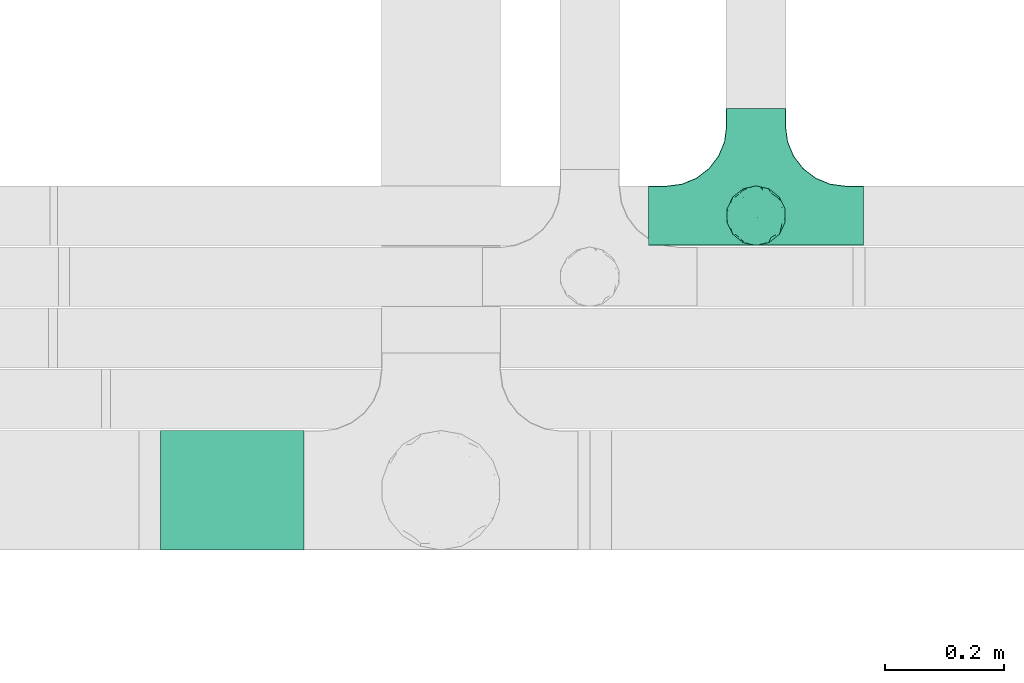
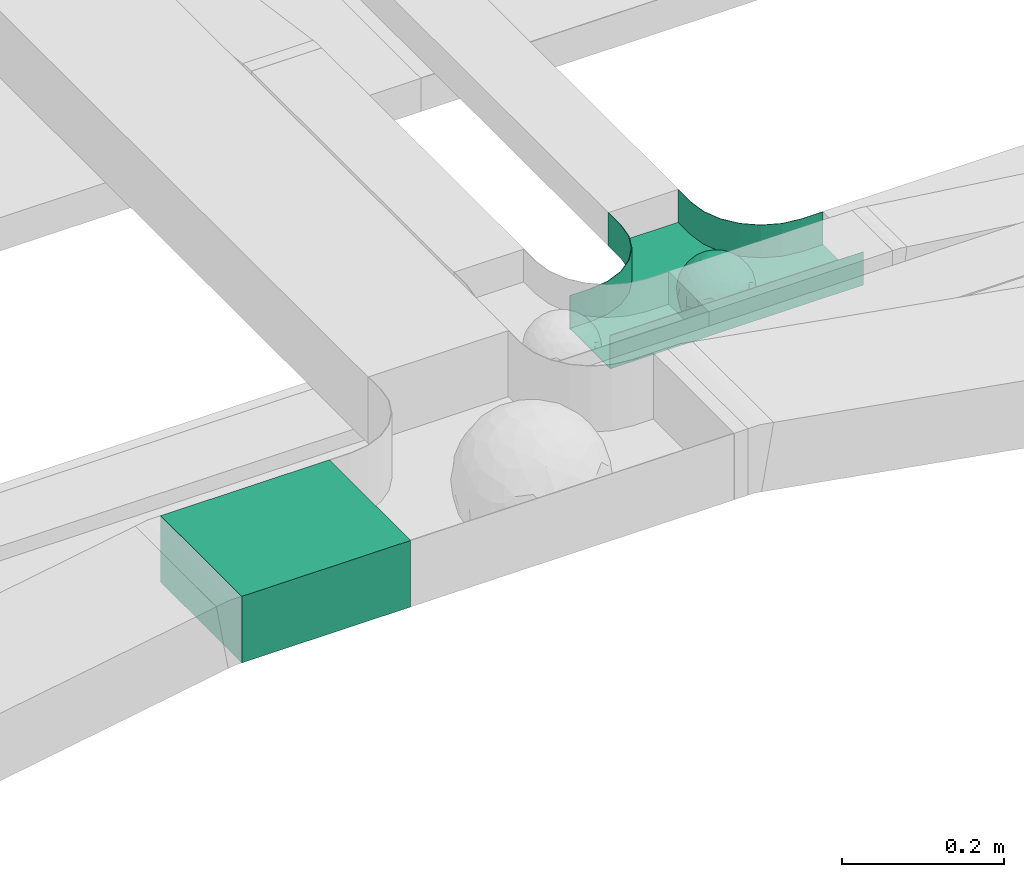
# One storey, part 13 of 38: 1 flow fitting, 1 flow segment.
"""IFC2X3 building model written with IfcOpenShell, lengths in millimetres."""

from ifc_helpers import new_model, entity, si_unit, converted_unit, derived_unit, direction, frame, frame_2d, origin, place, context, subcontext, project, spatial, rectangle, extrude, faceted_brep, source, transform, mapped, material, material_list, type_object, type_shapes, element, save


model = new_model("IFC2X3")

# Units and contexts
model_context = context("Model", 3, precision=0.01, world=origin(), true_north=direction((6.12303176911189e-17, 1.0)))
body_context = subcontext(model_context, "Body", "Model", "MODEL_VIEW")
ifc_project = project(units=[si_unit("LENGTHUNIT", "METRE", prefix="MILLI"), si_unit("AREAUNIT", "SQUARE_METRE"), si_unit("VOLUMEUNIT", "CUBIC_METRE"), converted_unit("PLANEANGLEUNIT", "DEGREE", entity("IfcRatioMeasure", 0.0174532925199433), si_unit("PLANEANGLEUNIT", "RADIAN"), dimensions=[0, 0, 0, 0, 0, 0, 0]), si_unit("MASSUNIT", "GRAM", prefix="KILO"), derived_unit("MASSDENSITYUNIT", [(si_unit("MASSUNIT", "GRAM", prefix="KILO"), 1), (si_unit("LENGTHUNIT", "METRE"), -3)]), derived_unit("MOMENTOFINERTIAUNIT", [(si_unit("LENGTHUNIT", "METRE"), 4)]), si_unit("TIMEUNIT", "SECOND"), si_unit("FREQUENCYUNIT", "HERTZ"), si_unit("THERMODYNAMICTEMPERATUREUNIT", "DEGREE_CELSIUS"), derived_unit("THERMALTRANSMITTANCEUNIT", [(si_unit("MASSUNIT", "GRAM", prefix="KILO"), 1), (si_unit("THERMODYNAMICTEMPERATUREUNIT", "KELVIN"), -1), (si_unit("TIMEUNIT", "SECOND"), -3)]), derived_unit("VOLUMETRICFLOWRATEUNIT", [(si_unit("LENGTHUNIT", "METRE"), 3), (si_unit("TIMEUNIT", "SECOND"), -1)]), derived_unit("MASSFLOWRATEUNIT", [(si_unit("MASSUNIT", "GRAM", prefix="KILO"), 1), (si_unit("TIMEUNIT", "SECOND"), -1)]), derived_unit("ROTATIONALFREQUENCYUNIT", [(si_unit("TIMEUNIT", "SECOND"), -1)]), si_unit("ELECTRICCURRENTUNIT", "AMPERE"), si_unit("ELECTRICVOLTAGEUNIT", "VOLT"), si_unit("POWERUNIT", "WATT"), si_unit("FORCEUNIT", "NEWTON", prefix="KILO"), si_unit("ILLUMINANCEUNIT", "LUX"), si_unit("LUMINOUSFLUXUNIT", "LUMEN"), si_unit("LUMINOUSINTENSITYUNIT", "CANDELA"), derived_unit("USERDEFINED", [(si_unit("MASSUNIT", "GRAM", prefix="KILO"), -1), (si_unit("LENGTHUNIT", "METRE"), -2), (si_unit("TIMEUNIT", "SECOND"), 3), (si_unit("LUMINOUSFLUXUNIT", "LUMEN"), 1)]), derived_unit("LINEARVELOCITYUNIT", [(si_unit("LENGTHUNIT", "METRE"), 1), (si_unit("TIMEUNIT", "SECOND"), -1)]), si_unit("PRESSUREUNIT", "PASCAL"), derived_unit("USERDEFINED", [(si_unit("LENGTHUNIT", "METRE"), -2), (si_unit("MASSUNIT", "GRAM", prefix="KILO"), 1), (si_unit("TIMEUNIT", "SECOND"), -2)]), derived_unit("LINEARFORCEUNIT", [(si_unit("MASSUNIT", "GRAM", prefix="KILO"), 1), (si_unit("LENGTHUNIT", "METRE"), 1), (si_unit("TIMEUNIT", "SECOND"), -2), (si_unit("LENGTHUNIT", "METRE"), -1)]), derived_unit("PLANARFORCEUNIT", [(si_unit("MASSUNIT", "GRAM", prefix="KILO"), 1), (si_unit("LENGTHUNIT", "METRE"), 1), (si_unit("TIMEUNIT", "SECOND"), -2), (si_unit("LENGTHUNIT", "METRE"), -2)])], contexts=[model_context])

# Site, building, storey
site_placement = place(None, frame((0.0, -0.00077364408347762, 0.0)))
site = spatial("IfcSite", under=ifc_project, at=site_placement, CompositionType="ELEMENT")
building_placement = place(site_placement, origin())
building = spatial("IfcBuilding", under=site, at=building_placement, CompositionType="ELEMENT")
storey_placement = place(building_placement, frame((0.0, 0.0, 4200.0)))
storey = spatial("IfcBuildingStorey", under=building, at=storey_placement, CompositionType="ELEMENT", Elevation=4200.0)

# Flow segment
cable_carrier_segment_type = type_object("IfcCableCarrierSegmentType", PredefinedType="CABLETRAYSEGMENT")
flow_segment_placement = place(storey_placement, frame((14113.434285659, 11443.7857236441, 2904.05791329438)))
element("IfcFlowSegment", 1, at=flow_segment_placement, inside=storey, type_object=cable_carrier_segment_type, context=body_context, shape_type="SweptSolid", body=[
    extrude(rectangle(XDim=240.106415937877, YDim=200.000000000002, at=frame_2d((1.08002495835535e-12, 0.0), x_axis=(1.0, 0.0))), frame((120.053207968937, 100.0, 0.0), z_axis=(0.0, 0.0, 1.0), x_axis=(-1.0, 0.0, 0.0)), (0.0, 0.0, 1.0), 99.9999999999989),
])

# Flow fitting
ifc_material_1 = material()
ifc_material_2 = material()
ifc_material_list = material_list([ifc_material_1, ifc_material_2])
cable_carrier_fitting_type = type_object("IfcCableCarrierFittingType", PredefinedType="NOTDEFINED", material=ifc_material_1)
shared_shape = source(origin(), body_context, "Body", "Brep", [
    faceted_brep([(43.65414201495, -13.6159823941412, -20.221792907194), (44.7734537304832, 0.0, -22.2561865791168), (48.2627667869764, -5.5982238187369, -11.8053052540677), (16.6591030416451, 5.32882774998004, -46.8409850521773), (11.5556000970565, -8.32997143460759, -47.9278591457525), (2.01883462715812, 2.6979389970297, -49.8863250993269), (-7.81264210311725, -35.946586740035, -33.8645171988286), (-17.2052206683237, -38.2719861359275, -27.1888848422606), (-11.1277274207927, -27.3202044092451, -40.3705352142543), (37.7030088371667, -7.24923843471304, -32.0301680723234), (10.6384317789277, 26.5155476513889, -41.0335168128579), (19.2127839264957, 19.8412508508062, -41.6796556903778), (10.4192511908907, 17.8098221318595, -45.5439286870577), (48.7463956090969, 0.0, 0.0), (48.0667721403428, 6.51594663441988, -12.1296271775358), (-37.4554170352858, 12.1627069007925, -30.8084451986326), (-31.3452178059555, 12.1462454498318, -37.0127821457472), (-38.0909108580228, 3.52194087904066, -32.1974912446565), (48.7463956090969, 11.1260466978072, 0.0), (9.66670567763161, 42.5651334019307, -24.3877883338551), (17.4761229293595, 37.974251726212, -27.4324868211278), (8.3452685270067, 35.3634447252368, -34.3479733081336), (36.7018152786982, 20.4309971840494, -27.121045505536), (28.2201055605836, 12.5803931374896, -39.3110588849404), (28.3969378462537, 24.0066360557188, -33.4259681422047), (37.1036906899333, 7.75177236926259, -32.6071489449891), (30.3928805396455, 38.1114667440203, 0.0), (34.7422273315263, 34.6429784184742, 0.0), (32.9402906787036, 32.1278050479557, -19.5637775698511), (26.0435337477646, 41.5799550695664, 0.0), (-44.7734518080776, 0.0, -22.2561904464559), (-35.9183276906112, -8.71634506105637, -33.6734177755349), (-42.698067512074, -12.1858404892465, -22.9865247983333), (5.42354673897514, -48.7621108487887, 0.0), (2.92058716488888e-07, -48.7843224693665, -10.9585528791684), (7.58713024513234, -47.4313421101439, -13.8817592643935), (33.995370401777, -31.6485911362954, -18.5116576873667), (40.0066375577234, -26.2448741379086, -14.5146661281262), (30.3928805396453, -38.1114667440373, 0.0), (-47.5540080368347, -8.6499737676748, -12.798213682019), (43.918984866252, -21.1502683953847, 0.0), (-47.5463631702337, 8.67950108284767, -12.8066236860544), (-43.9189848662407, 21.1502683953677, 0.0), (-41.5587306666804, 23.544384411141, -14.7828910593852), (-36.7018137075475, 20.43099797302, -27.1210470373429), (-42.6812093094125, 12.162707383776, -23.0300438771125), (-0.0435489182880873, -44.6798423199703, -22.4434799831651), (43.3459115209922, 13.125713179152, -21.1860238825719), (-9.67158541810518, -42.815796006327, -23.9430166822217), (2.9348104480415, -38.3026865671621, -32.0045479482528), (10.5768620896568, -32.3565839798164, -36.6221444141874), (17.476122931187, -37.9742517249799, -27.4324868216925), (29.4150529887209, -14.2918330913411, -37.8219270339311), (29.2594402117981, 0.0, -40.5448536622337), (-34.742227331515, 34.6429784184742, 0.0), (-35.5934709721032, 30.8679809236437, -16.7413433706631), (16.2706402169142, 46.2863325463322, 0.0), (15.3978227309257, 45.3692296018892, -14.301750259225), (10.8470934779447, 47.524221697552, 0.0), (-22.0930685137321, 42.2576087042555, -15.0396419586498), (-16.2706402169028, 46.2863325463322, 0.0), (-15.3976096147999, 45.3685960862683, -14.3039892096614), (-35.5741674477324, -30.877857614309, -16.7641438657341), (-34.7422273315149, -34.6429784184913, 0.0), (-41.544749127214, -23.5699215759022, -14.7814957586296), (-21.2012609977656, -29.9118129495041, -33.9969113035032), (-22.0930685137892, -42.2576087036302, -15.0396419603704), (-28.5890959469058, -35.7745555449591, -20.0709932115786), (27.967317375364, -26.9235432392394, -31.5111405422078), (26.5630985649032, -36.7540375314827, -21.0604491824418), (-4.69743067705244, -12.8233951627736, -48.0988012484001), (-3.71385705669819, -22.0483048804436, -44.7222485756373), (7.046128924104e-07, -29.8515321197025, -40.1109215813634), (-8.78090686085946, 23.4705297392872, -43.266960933916), (-10.7087237416586, 12.1533783795858, -47.3034737602475), (-19.1851128431225, 19.8122800241045, -41.7061746680507), (19.2127839279743, -19.841250849511, -41.6796556903208), (10.2736167511021, -43.2535488218696, -22.8819429499797), (-16.2706402169027, -46.2863325463492, 0.0), (-15.4179487650123, -45.4307793041134, -14.0830091848577), (-10.8470934779332, -47.524221697569, 0.0), (-21.6941869558721, -45.0484433951294, 0.0), (-26.043533747753, -41.5799550695834, 0.0), (-30.3928805396339, -38.1114667440373, 0.0), (-26.9077773704145, -11.7097120961444, -40.4827637348157), (-28.5735237959864, -22.531789977659, -34.2909926698312), (-14.3485559949731, 0.554718003800719, -47.8937493708156), (20.3912706461748, 29.6966950280778, -34.6742323035854), (25.8798715159051, 35.5620355309087, -23.7817972243053), (-1.90439589452332, 38.2956374757213, -32.090768557389), (-0.0435489197807358, 44.6798423204566, -22.4434799821603), (-9.54280395759116, 42.6678856642021, -24.2566779582937), (-10.1209262269152, 33.0365306692783, -36.140759450321), (-17.2052206685055, 38.2719861378047, -27.1888848394794), (-28.5890959468196, 35.7745555453602, -20.0709932109564), (-30.3928805396341, 38.1114667440203, 0.0), (-26.0435337477532, 41.5799550695664, 0.0), (-21.6941869558723, 45.0484433951125, 0.0), (0.920553890736952, 16.9936143333855, -47.0145685125519), (7.01705705346737e-07, 29.8515321215381, -40.1109215799846), (-28.4299335912282, 23.6392950735915, -33.6589156750601), (22.0754283900311, -42.7194435884069, -13.7012627481666), (0.0, -50.0, 0.0), (-7.98433520770671, 47.2879675743241, -14.1456181900809), (-10.8470934779333, 47.524221697552, 0.0), (-5.42354673896381, 48.7621108487718, 0.0), (-39.0915741233958, -31.1744900929452, 0.0), (-36.7018137083218, -20.4309979729983, -27.1210470363242), (-20.0503020227076, 29.8835350153312, -34.7125297808217), (48.7463956090969, -11.1260466978243, 0.0), (36.7018152787698, -20.430997183803, -27.1210455056374), (39.0915741234071, -31.1744900929452, 0.0), (43.9189848662521, 21.1502683953677, 0.0), (41.0372234357161, 24.481336168204, -14.7176924857918), (21.4315363761966, -9.86715979165204, -44.0831986838696), (19.8461085062156, -30.3026908878047, -34.4656191315041), (26.0435337477644, -41.5799550695834, 0.0), (8.27678352490751, -22.6176025005053, -43.8171075221857), (-19.1851128386707, -19.8122800229913, -41.7061746706354), (-17.559283921422, -9.66340012518247, -45.8070982074481), (-29.2594384269524, -1.64502744759432e-09, -40.5448549502702), (-22.2759109836818, 8.45458562997746, -43.957977338265), (21.6941869558835, -45.0484433951294, 0.0), (-7.7537430917927, -47.3248906716555, -14.1504131029038), (22.0929359888287, 42.3611643932195, -14.7456410726513), (21.6941869558837, 45.0484433951125, 0.0), (7.94480963874029, 47.2524194975214, -14.285966940796), (5.42354673897518, 48.7621108487718, 0.0), (-43.9189848662406, -21.1502683953848, 0.0), (-39.0915741233959, 31.1744900929281, 0.0), (-48.7463956090855, 11.1260466978072, 0.0), (-48.7463956090855, -11.1260466978243, 0.0), (-48.7463956090855, 0.0, 0.0), (0.0, 50.0, 0.0), (2.95674852821199e-07, 48.76542105366, -11.0423597776141), (-5.42354673896377, -48.7621108487887, 0.0), (16.2706402169141, -46.2863325463492, 0.0), (10.8470934779446, -47.524221697569, 0.0), (39.0915741234072, 31.1744900929281, 0.0), (34.7422273315262, -34.6429784184913, 0.0), (-43.6541417785539, -13.6159824952714, 20.2217933494142), (-44.7734534735007, 0.0, 22.2561870960884), (-48.2627667188257, -5.59822380837423, 11.8053055375658), (-16.6591016552529, 5.32882757852047, 46.8409855647676), (-11.5555985538933, -8.32997141356845, 47.9278595214841), (-2.01883285210585, 2.69793886619285, 49.8863251782511), (7.81264298940045, -35.9465866899564, 33.8645170475355), (17.2052219498432, -38.2719853643866, 27.1888851173795), (11.1277291939633, -27.3202042660781, 40.370534822402), (-37.7030082707847, -7.24923849358482, 32.0301687256941), (-10.6384306361632, 26.5155474098453, 41.0335172652288), (-19.2127828542464, 19.8412506695278, 41.6796562709507), (-10.419249902145, 17.8098220464058, 45.5439290153173), (-48.0667720467311, 6.51594672713361, 12.1296274986609), (37.4554198551597, 12.1627053911885, 30.8084423663635), (31.3452204336626, 12.1462444514283, 37.0127802480704), (38.0909129847824, 3.52193921618223, 32.1974889105362), (-9.66670492251031, 42.565133342123, 24.3877887375616), (-17.4761222809685, 37.9742516795029, 27.4324872988574), (-8.34526747232003, 35.3634445391436, 34.3479737559899), (-36.7018147879525, 20.4309972885889, 27.1210460908894), (-28.2201045883605, 12.5803929822385, 39.3110596325575), (-28.3969371324566, 24.0066357536882, 33.4259689655335), (-37.1036900366786, 7.75177247673037, 32.6071496627812), (-32.9402901163369, 32.1278052689131, 19.5637781538672), (44.773453728735, 0.0, 22.2561865826485), (35.9183286182219, -8.71634518545332, 33.6734167539099), (42.6980684782056, -12.1858381773451, 22.9865242293622), (-5.1564557811304e-08, -48.7843224155168, 10.9585531189064), (-7.58712982046247, -47.4313421866568, 13.8817592350767), (-33.9953700157816, -31.6485912778883, 18.5116581541388), (-40.0066373233245, -26.2448743223541, 14.5146664406737), (47.5540088657557, -8.64997340643016, 12.7982108462298), (47.5463641063755, 8.67950029611492, 12.8066207437518), (41.5587323717035, 23.5443822102692, 14.7828897714275), (36.7018153946169, 20.4309968399072, 27.121045607934), (42.6812105193328, 12.1627054070682, 23.0300426787683), (0.0435498934198039, -44.6798421141237, 22.4434803910813), (-43.3459112327239, 13.1257132261269, 21.1860244432478), (9.6715868653752, -42.8157959611257, 23.9430161784588), (-2.93481023367521, -38.3026862522726, 32.0045483447802), (-10.5768615382775, -32.3565831315815, 36.6221453228799), (-17.4761222811971, -37.9742516793303, 27.4324872989742), (-29.4150522011614, -14.2918331221065, 37.8219276348162), (-29.259439267976, 0.0, 40.5448543433553), (35.593472529025, 30.867979902287, 16.7413419437535), (-15.3978225621776, 45.3692295068837, 14.3017507422931), (22.0930688164668, 42.2576085856364, 15.0396418472572), (15.3976099169387, 45.3685960801975, 14.3039889037045), (35.5741692798952, -30.8778564526781, 16.7641421174582), (41.5447510295928, -23.5699190140567, 14.7814944968718), (21.2012629219892, -29.9118119699372, 33.9969109653959), (22.0930688164889, -42.2576085855628, 15.039641847479), (28.5890966709526, -35.7745557157875, 20.0709918757936), (-27.9673166448933, -26.9235432178776, 31.5111412087844), (-26.5630981091642, -36.7540374223405, 21.0604499477277), (4.69743244094294, -12.8233948182002, 48.0988011680158), (3.71385918047916, -22.0483045188225, 44.7222485775695), (6.0892732202368e-07, -29.8515316280668, 40.1109219472655), (8.78090833347225, 23.4705290601204, 43.2669610034903), (10.7087255323208, 12.1533779204354, 47.3034734728551), (19.1851144535653, 19.8122792782791, 41.7061742815566), (-19.212782854423, -19.8412506693283, 41.6796562709723), (-10.2736163541564, -43.2535491498667, 22.8819425082012), (15.4179491053271, -45.430779442795, 14.0830083649343), (26.9077783310918, -11.7097109554472, 40.4827634262511), (28.5735255699879, -22.531788297607, 34.2909922955619), (14.3485579041194, 0.554717908736034, 47.893748799971), (-20.3912698186306, 29.6966949125693, 34.674232889184), (-25.8798708903081, 35.5620354347035, 23.7817980489561), (1.90439718168615, 38.2956370656312, 32.0907689704016), (0.0435498935700709, 44.6798421141929, 22.4434803909095), (9.54280511870019, 42.6678852802435, 24.2566781769111), (10.1209277017953, 33.036529901429, 36.1407597392074), (17.2052219497738, 38.2719853646937, 27.1888851169673), (28.5890966709116, 35.7745557157488, 20.0709918758907), (-0.920552500958269, 16.993613961591, 47.0145686741652), (6.09264554473049e-07, 29.8515316283504, 40.1109219470418), (28.4299352793349, 23.6392936643312, 33.6589152389788), (-22.0754282965694, -42.7194435788052, 13.7012629286858), (7.9843354212563, 47.2879674404261, 14.1456185171795), (36.7018153946056, -20.4309968401043, 27.1210456078136), (20.0503035663584, 29.8835340747136, 34.7125296989797), (-36.7018147879654, -20.4309972885437, 27.1210460909186), (-41.0372232425556, 24.4813362747081, 14.7176928472045), (-21.4315352776288, -9.8671595900376, 44.0831992630873), (-19.8461080318002, -30.3026912052829, 34.4656191255603), (-8.27678185920825, -22.617601585775, 43.8171083090061), (19.1851144530605, -19.8122792780652, 41.7061742818985), (17.5592847966676, -9.6634000411993, 45.8070978896755), (29.259440221343, 0.0, 40.5448536553604), (22.2759127990671, 8.45458631346954, 43.9579762868721), (7.75374356219277, -47.3248906381916, 14.1504129570858), (-22.0929358819219, 42.3611643749655, 14.7456412852645), (-7.94480944914509, 47.2524194744515, 14.2859671225497), (-5.23333520595152e-08, 48.7654210084985, 11.0423599770715)], [[[0, 1, 2]], [[3, 4, 5]], [[6, 7, 8]], [[1, 0, 9]], [[10, 11, 12]], [[13, 2, 14]], [[15, 16, 17]], [[14, 18, 13]], [[19, 20, 21]], [[22, 23, 24]], [[1, 9, 25]], [[26, 27, 28, 29]], [[30, 31, 32]], [[33, 34, 35]], [[36, 37, 38]], [[32, 39, 30]], [[2, 40, 0]], [[23, 22, 25]], [[41, 42, 43]], [[44, 15, 45]], [[46, 35, 34]], [[25, 22, 47]], [[31, 30, 17]], [[48, 49, 46]], [[50, 51, 49]], [[52, 53, 9]], [[43, 54, 55]], [[56, 57, 58]], [[59, 60, 61]], [[62, 63, 64]], [[8, 7, 65]], [[7, 66, 67]], [[68, 36, 69]], [[70, 5, 4]], [[8, 71, 72]], [[73, 74, 75]], [[68, 76, 52]], [[77, 46, 49]], [[78, 79, 80]], [[7, 6, 48]], [[67, 81, 82, 83]], [[84, 85, 31]], [[85, 65, 67]], [[70, 86, 5]], [[23, 3, 11]], [[21, 87, 10]], [[21, 20, 87]], [[28, 24, 88]], [[19, 89, 90]], [[91, 90, 89]], [[91, 92, 93]], [[94, 95, 96, 97]], [[98, 99, 10]], [[100, 16, 44]], [[77, 51, 101]], [[33, 102, 34]], [[103, 91, 61]], [[93, 59, 61]], [[104, 105, 103]], [[106, 64, 63]], [[107, 31, 85]], [[100, 94, 108]], [[108, 93, 92]], [[43, 55, 44]], [[0, 40, 37]], [[2, 13, 109]], [[2, 1, 14]], [[110, 9, 0]], [[2, 109, 40]], [[37, 40, 111]], [[47, 14, 1]], [[112, 14, 47]], [[113, 112, 47]], [[112, 18, 14]], [[47, 22, 113]], [[52, 9, 110]], [[53, 25, 9]], [[25, 47, 1]], [[23, 25, 53]], [[68, 52, 110]], [[76, 4, 114]], [[51, 115, 69]], [[50, 115, 51]], [[110, 36, 68]], [[3, 23, 53]], [[23, 11, 24]], [[52, 76, 114]], [[98, 12, 5]], [[11, 87, 24]], [[24, 28, 22]], [[87, 88, 24]], [[36, 116, 69]], [[28, 27, 113]], [[114, 3, 53]], [[76, 115, 117]], [[70, 4, 117]], [[118, 84, 119]], [[119, 70, 118]], [[120, 16, 121]], [[37, 36, 110]], [[116, 36, 38]], [[116, 122, 69]], [[34, 123, 46]], [[10, 87, 11]], [[87, 20, 88]], [[12, 98, 10]], [[10, 99, 21]], [[74, 5, 86]], [[73, 75, 108]], [[124, 56, 125]], [[124, 29, 88]], [[89, 21, 99]], [[21, 89, 19]], [[92, 89, 99]], [[89, 92, 91]], [[126, 127, 58]], [[88, 29, 28]], [[20, 57, 124]], [[88, 20, 124]], [[57, 20, 19]], [[73, 92, 99]], [[92, 73, 108]], [[99, 98, 73]], [[74, 86, 121]], [[73, 98, 74]], [[5, 74, 98]], [[100, 108, 75]], [[94, 93, 108]], [[86, 120, 121]], [[100, 44, 55]], [[75, 16, 100]], [[17, 16, 120]], [[31, 17, 120]], [[17, 30, 45]], [[84, 31, 120]], [[31, 107, 32]], [[41, 45, 30]], [[43, 44, 45]], [[107, 64, 32]], [[39, 64, 128]], [[30, 39, 41]], [[129, 43, 42]], [[41, 130, 42]], [[43, 45, 41]], [[62, 83, 63]], [[95, 94, 55]], [[100, 55, 94]], [[64, 107, 62]], [[131, 39, 128]], [[64, 106, 128]], [[85, 62, 107]], [[67, 83, 62]], [[39, 32, 64]], [[130, 41, 132]], [[59, 97, 60]], [[133, 127, 134]], [[59, 94, 97]], [[104, 61, 60]], [[94, 59, 93]], [[126, 134, 127]], [[126, 58, 57]], [[19, 90, 126]], [[134, 105, 133]], [[126, 90, 134]], [[103, 90, 91]], [[105, 134, 103]], [[90, 103, 134]], [[119, 120, 86]], [[84, 118, 85]], [[65, 85, 118]], [[62, 85, 67]], [[8, 65, 118]], [[67, 65, 7]], [[71, 118, 70]], [[8, 72, 6]], [[49, 6, 72]], [[6, 49, 48]], [[50, 49, 72]], [[77, 49, 51]], [[101, 69, 122]], [[123, 34, 135]], [[101, 122, 136]], [[137, 77, 136]], [[78, 81, 66]], [[7, 79, 66]], [[67, 66, 81]], [[79, 7, 48]], [[35, 137, 33]], [[123, 80, 79]], [[135, 34, 102]], [[35, 46, 77]], [[80, 123, 135]], [[46, 123, 48]], [[117, 50, 72]], [[115, 76, 68]], [[117, 72, 71]], [[4, 76, 117]], [[39, 132, 41]], [[39, 131, 132]], [[137, 35, 77]], [[124, 57, 56]], [[126, 57, 19]], [[103, 61, 104]], [[61, 91, 93]], [[77, 101, 136]], [[51, 69, 101]], [[28, 113, 22]], [[112, 113, 138]], [[16, 75, 121]], [[74, 121, 75]], [[66, 79, 78]], [[123, 79, 48]], [[0, 37, 110]], [[37, 111, 139, 38]], [[29, 124, 125]], [[115, 50, 117]], [[69, 115, 68]], [[120, 119, 84]], [[70, 119, 86]], [[11, 3, 12]], [[5, 12, 3]], [[118, 71, 8]], [[117, 71, 70]], [[3, 114, 4]], [[53, 52, 114]], [[27, 138, 113]], [[45, 15, 17]], [[44, 16, 15]], [[55, 54, 95]], [[43, 129, 54]], [[140, 141, 142]], [[143, 144, 145]], [[146, 147, 148]], [[141, 140, 149]], [[150, 151, 152]], [[132, 142, 153]], [[154, 155, 156]], [[153, 130, 132]], [[157, 158, 159]], [[160, 161, 162]], [[141, 149, 163]], [[95, 54, 164, 96]], [[165, 166, 167]], [[135, 168, 169]], [[170, 171, 83]], [[167, 172, 165]], [[142, 141, 153]], [[161, 160, 163]], [[173, 112, 174]], [[175, 154, 176]], [[177, 169, 168]], [[163, 160, 178]], [[166, 165, 156]], [[179, 180, 177]], [[181, 182, 180]], [[183, 184, 149]], [[174, 27, 185]], [[60, 186, 104]], [[187, 56, 188]], [[189, 139, 190]], [[148, 147, 191]], [[147, 192, 193]], [[194, 170, 195]], [[196, 145, 144]], [[148, 197, 198]], [[199, 200, 201]], [[194, 202, 183]], [[203, 177, 180]], [[136, 204, 137]], [[147, 146, 179]], [[193, 122, 116, 38]], [[205, 206, 166]], [[206, 191, 193]], [[196, 207, 145]], [[161, 143, 151]], [[159, 208, 150]], [[159, 158, 208]], [[164, 162, 209]], [[157, 210, 211]], [[212, 211, 210]], [[212, 213, 214]], [[215, 26, 29, 125]], [[216, 217, 150]], [[218, 155, 175]], [[203, 182, 219]], [[135, 102, 168]], [[220, 212, 188]], [[214, 187, 188]], [[58, 127, 220]], [[111, 190, 139]], [[221, 166, 206]], [[218, 215, 222]], [[222, 214, 213]], [[174, 185, 175]], [[171, 140, 128]], [[132, 131, 142]], [[142, 128, 140]], [[223, 149, 140]], [[142, 131, 128]], [[171, 128, 106]], [[178, 153, 141]], [[42, 153, 178]], [[224, 42, 178]], [[42, 130, 153]], [[178, 160, 224]], [[183, 149, 223]], [[184, 163, 149]], [[163, 178, 141]], [[161, 163, 184]], [[194, 183, 223]], [[202, 144, 225]], [[182, 226, 195]], [[181, 226, 182]], [[223, 170, 194]], [[143, 161, 184]], [[161, 151, 162]], [[183, 202, 225]], [[216, 152, 145]], [[151, 208, 162]], [[162, 164, 160]], [[208, 209, 162]], [[170, 82, 195]], [[164, 54, 224]], [[225, 143, 184]], [[202, 226, 227]], [[196, 144, 227]], [[228, 205, 229]], [[229, 196, 228]], [[230, 155, 231]], [[171, 170, 223]], [[82, 170, 83]], [[82, 81, 195]], [[168, 232, 177]], [[150, 208, 151]], [[208, 158, 209]], [[152, 216, 150]], [[150, 217, 159]], [[200, 145, 207]], [[199, 201, 222]], [[233, 60, 97]], [[233, 96, 209]], [[210, 159, 217]], [[159, 210, 157]], [[213, 210, 217]], [[210, 213, 212]], [[234, 105, 104]], [[209, 96, 164]], [[158, 186, 233]], [[209, 158, 233]], [[186, 158, 157]], [[199, 213, 217]], [[213, 199, 222]], [[217, 216, 199]], [[200, 207, 231]], [[199, 216, 200]], [[145, 200, 216]], [[218, 222, 201]], [[215, 214, 222]], [[207, 230, 231]], [[218, 175, 185]], [[201, 155, 218]], [[156, 155, 230]], [[166, 156, 230]], [[156, 165, 176]], [[205, 166, 230]], [[166, 221, 167]], [[173, 176, 165]], [[174, 175, 176]], [[221, 190, 167]], [[172, 190, 40]], [[165, 172, 173]], [[138, 174, 112]], [[173, 18, 112]], [[174, 176, 173]], [[189, 38, 139]], [[26, 215, 185]], [[218, 185, 215]], [[190, 221, 189]], [[109, 172, 40]], [[190, 111, 40]], [[206, 189, 221]], [[193, 38, 189]], [[172, 167, 190]], [[18, 173, 13]], [[187, 125, 56]], [[133, 105, 235]], [[187, 215, 125]], [[58, 188, 56]], [[215, 187, 214]], [[234, 235, 105]], [[234, 104, 186]], [[157, 211, 234]], [[235, 127, 133]], [[234, 211, 235]], [[220, 211, 212]], [[127, 235, 220]], [[211, 220, 235]], [[229, 230, 207]], [[205, 228, 206]], [[191, 206, 228]], [[189, 206, 193]], [[148, 191, 228]], [[193, 191, 147]], [[197, 228, 196]], [[148, 198, 146]], [[180, 146, 198]], [[146, 180, 179]], [[181, 180, 198]], [[203, 180, 182]], [[219, 195, 81]], [[232, 168, 33]], [[219, 81, 78]], [[80, 203, 78]], [[136, 122, 192]], [[147, 204, 192]], [[193, 192, 122]], [[204, 147, 179]], [[169, 80, 135]], [[232, 137, 204]], [[33, 168, 102]], [[169, 177, 203]], [[137, 232, 33]], [[177, 232, 179]], [[227, 181, 198]], [[226, 202, 194]], [[227, 198, 197]], [[144, 202, 227]], [[172, 13, 173]], [[172, 109, 13]], [[80, 169, 203]], [[233, 186, 60]], [[234, 186, 157]], [[220, 188, 58]], [[188, 212, 214]], [[203, 219, 78]], [[182, 195, 219]], [[164, 224, 160]], [[42, 224, 129]], [[155, 201, 231]], [[200, 231, 201]], [[192, 204, 136]], [[232, 204, 179]], [[140, 171, 223]], [[171, 106, 63, 83]], [[96, 233, 97]], [[226, 181, 227]], [[195, 226, 194]], [[230, 229, 205]], [[196, 229, 207]], [[151, 143, 152]], [[145, 152, 143]], [[228, 197, 148]], [[227, 197, 196]], [[143, 225, 144]], [[184, 183, 225]], [[54, 129, 224]], [[176, 154, 156]], [[175, 155, 154]], [[185, 27, 26]], [[174, 138, 27]]]),
    faceted_brep([(-53.4074173710859, -124.118095489752, 25.0), (-50.0, -150.0, 25.0), (-50.0, -180.0, 25.0), (-49.1999999999934, -180.0, 25.0), (-49.1999999999926, -150.0, 25.0), (-52.6346767100545, -123.91104025367, 25.0), (-62.7046392985216, -99.6000000000037, 25.0), (-78.7236364563899, -78.7236364563991, 25.0), (-99.5999999999949, -62.7046392985315, 25.0), (-123.911040253662, -52.6346767100651, 25.0), (-150.0, -49.2000000000047, 25.0), (-180.0, -49.2000000000047, 25.0), (-180.0, -50.0, 25.0), (-150.0, -50.0, 25.0), (-124.118095489745, -53.4074173710983, 25.0), (-100.0, -63.3974596215602, 25.0), (-79.2893218813398, -79.2893218813488, 25.0), (-63.3974596215496, -100.0, 25.0), (180.0, -50.0, 25.0), (180.0, -49.2000000000047, 25.0), (150.0, -49.2000000000046, 25.0), (123.911040253717, -52.634676710066, 25.0), (99.6000000000452, -62.7046392985316, 25.0), (78.7236364564342, -78.7236364563979, 25.0), (62.7046392985581, -99.6000000000012, 25.0), (52.6346767100809, -123.911040253668, 25.0), (49.200000000007, -150.0, 25.0), (49.2000000000071, -180.0, 25.0), (50.0, -180.0, 25.0), (50.0, -150.0, 25.0), (53.4074173711136, -124.11809548975, 25.0), (63.3974596215874, -100.0, 25.0), (79.2893218813853, -79.2893218813486, 25.0), (100.0, -63.3974596215613, 25.0), (124.1180954898, -53.4074173710999, 25.0), (150.0, -50.0, 25.0), (180.0, 49.1999999999958, 25.0), (180.0, 50.0, 25.0), (-180.0, 50.0, 25.0), (-180.0, 49.1999999999958, 25.0), (-180.0, -50.0, -25.0), (-180.0, 50.0, -25.0), (180.0, 50.0, -25.0), (180.0, -50.0, -25.0), (150.0, -50.0, -25.0), (124.1180954898, -53.4074173710999, -25.0), (100.0, -63.3974596215613, -25.0), (79.2893218813853, -79.2893218813486, -25.0), (63.3974596215874, -100.0, -25.0), (53.4074173711136, -124.11809548975, -25.0), (50.0, -150.0, -25.0), (50.0, -180.0, -25.0), (-50.0, -180.0, -25.0), (-50.0, -150.0, -25.0), (-53.4074173710859, -124.118095489752, -25.0), (-63.3974596215496, -100.0, -25.0), (-79.2893218813398, -79.2893218813488, -25.0), (-100.0, -63.3974596215602, -25.0), (-124.118095489745, -53.4074173710983, -25.0), (-150.0, -50.0, -25.0), (-50.0, -150.0, -24.199999999986), (49.2000000000071, -180.0, -24.199999999986), (-49.1999999999934, -180.0, -24.199999999986), (-49.1999999999926, -150.0, -24.199999999986), (-150.0, -49.2000000000047, -24.199999999986), (-180.0, -49.2000000000047, -24.199999999986), (180.0, -49.2000000000047, -24.199999999986), (150.0, -49.2000000000047, -24.199999999986), (-180.0, 49.1999999999958, -24.199999999986), (-150.0, -50.0, -24.199999999986), (150.0, -50.0, -24.199999999986), (180.0, 49.1999999999958, -24.199999999986), (49.200000000007, -150.0, -24.199999999986), (50.0, -150.0, -24.199999999986), (-123.911040253662, -52.6346767100651, -24.199999999986), (-99.5999999999949, -62.7046392985315, -24.199999999986), (-78.7236364563899, -78.7236364563991, -24.199999999986), (-62.7046392985217, -99.6000000000036, -24.199999999986), (-52.6346767100546, -123.91104025367, -24.199999999986), (52.6346767100807, -123.911040253669, -24.199999999986), (62.7046392985577, -99.6000000000018, -24.199999999986), (78.7236364564338, -78.7236364563983, -24.199999999986), (99.6000000000446, -62.704639298532, -24.199999999986), (123.911040253716, -52.6346767100662, -24.199999999986)], [[[0, 1, 2, 3, 4, 5, 6, 7, 8, 9, 10, 11, 12, 13, 14, 15, 16, 17]], [[18, 19, 20, 21, 22, 23, 24, 25, 26, 27, 28, 29, 30, 31, 32, 33, 34, 35]], [[36, 37, 38, 39]], [[40, 41, 42, 43, 44, 45, 46, 47, 48, 49, 50, 51, 52, 53, 54, 55, 56, 57, 58, 59]], [[2, 1, 60, 53, 52]], [[3, 2, 52, 51, 28, 27, 61, 62]], [[4, 3, 62, 63]], [[11, 10, 64, 65]], [[20, 19, 66, 67]], [[39, 38, 41, 40, 12, 11, 65, 68]], [[13, 12, 40, 59, 69]], [[18, 35, 70, 44, 43]], [[19, 18, 43, 42, 37, 36, 71, 66]], [[27, 26, 72, 61]], [[29, 28, 51, 50, 73]], [[38, 37, 42, 41]], [[36, 39, 68, 71]], [[68, 65, 64, 74, 75, 76, 77, 78, 63, 62, 61, 72, 79, 80, 81, 82, 83, 67, 66, 71]], [[14, 13, 69, 59, 58]], [[58, 57, 15, 14]], [[15, 57, 56, 16]], [[0, 17, 55, 54]], [[0, 54, 53, 60, 1]], [[55, 17, 16, 56]], [[5, 4, 63, 78]], [[6, 5, 78, 77]], [[7, 6, 77, 76]], [[8, 7, 76, 75]], [[9, 8, 75, 74]], [[10, 9, 74, 64]], [[21, 20, 67, 83]], [[22, 21, 83, 82]], [[23, 22, 82, 81]], [[81, 80, 24, 23]], [[24, 80, 79, 25]], [[79, 72, 26, 25]], [[30, 29, 73, 50, 49]], [[31, 30, 49, 48]], [[31, 48, 47, 32]], [[33, 32, 47, 46]], [[45, 34, 33, 46]], [[34, 45, 44, 70, 35]]]),
])
type_shapes(cable_carrier_fitting_type, [shared_shape])
flow_fitting_placement = place(storey_placement, frame((15111.7657974395, 12004.0299176424, 2775.0), z_axis=(0.0, 0.0, 1.0), x_axis=(-1.0, 0.0, 0.0)))
element("IfcFlowFitting", 2, at=flow_fitting_placement, inside=storey, type_object=cable_carrier_fitting_type, material=ifc_material_list, Name="470_DKC_S5_T", context=body_context, shape_type="MappedRepresentation", body=[
    mapped(shared_shape, transform((0.0, 0.0, 0.0), scale=1.0)),
])

save(model, "model.ifc")
